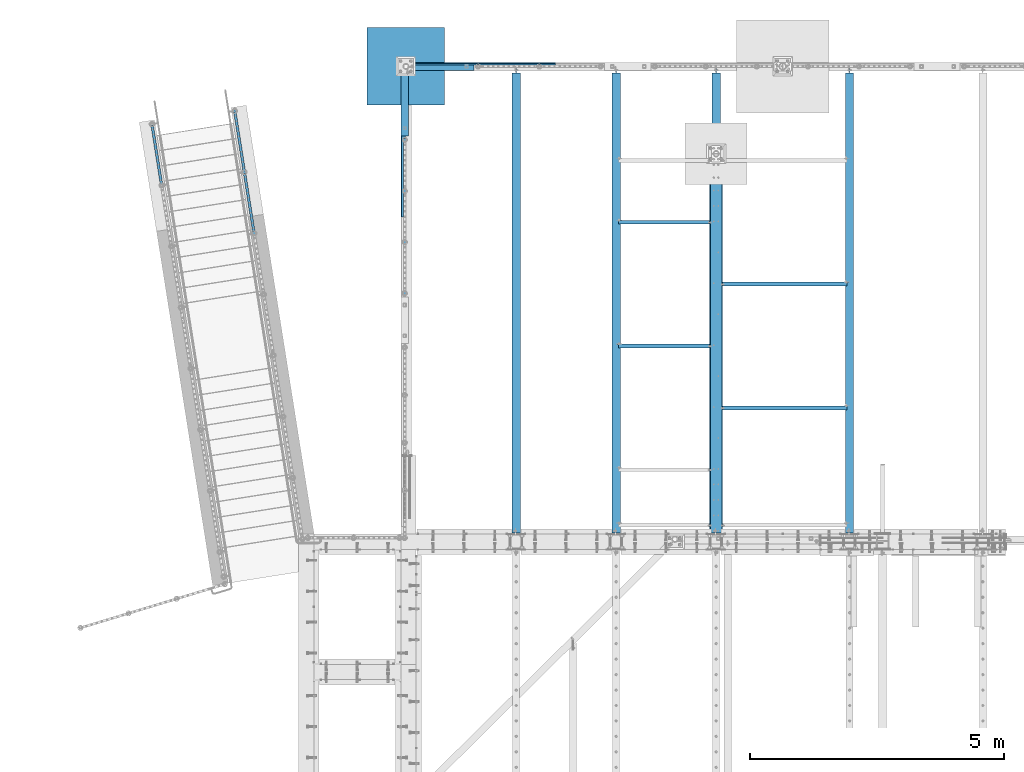
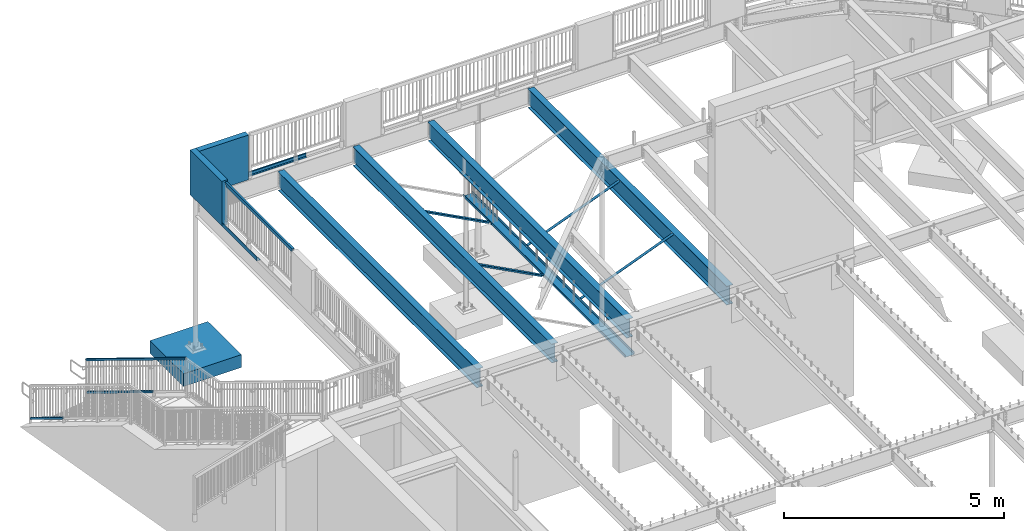
# One storey, part 324 of 975: 15 beams, 4 members.
"""IFC2X3 building model written with IfcOpenShell, lengths in millimetres."""

from ifc_helpers import new_model, si_unit, frame, origin_with_axes, place, context, subcontext, project, spatial, faceted_brep, material, type_object, element, save


model = new_model("IFC2X3")

# Units and contexts
model_context = context("Model", 3, precision=1e-05, world=origin_with_axes())
body_context = subcontext(model_context, "Body", "Model", "MODEL_VIEW")
ifc_project = project(units=[si_unit("LENGTHUNIT", "METRE", prefix="MILLI"), si_unit("AREAUNIT", "SQUARE_METRE"), si_unit("VOLUMEUNIT", "CUBIC_METRE"), si_unit("MASSUNIT", "GRAM", prefix="KILO"), si_unit("TIMEUNIT", "SECOND"), si_unit("PLANEANGLEUNIT", "RADIAN"), si_unit("SOLIDANGLEUNIT", "STERADIAN"), si_unit("THERMODYNAMICTEMPERATUREUNIT", "DEGREE_CELSIUS"), si_unit("LUMINOUSINTENSITYUNIT", "LUMEN")], contexts=[model_context])

# Site, building, storey
site_placement = place(None, origin_with_axes())
site = spatial("IfcSite", under=ifc_project, at=site_placement, CompositionType="ELEMENT")
building_placement = place(site_placement, origin_with_axes())
building = spatial("IfcBuilding", under=site, at=building_placement, Name="Undefined", CompositionType="ELEMENT")
storey_placement = place(building_placement, origin_with_axes())
storey = spatial("IfcBuildingStorey", under=building, at=storey_placement, Name="Undefined", CompositionType="ELEMENT", Elevation=0.0)

# Beams
ifc_material_1 = material(Name="STEEL/A36")
beam_type_1 = type_object("IfcBeamType", Name="L3X3X3/16", PredefinedType="NOTDEFINED")
for number, where, z_axis, x_axis, name in (
    (1, (8064.5, 24454.64375, 2870.2), (-0.999999999999998, 6.90000001668524e-08, 0.0), (0.0, 0.0, 1.0), "ANGLE"),
    (2, (8064.5, 26893.04375, 2870.2), (-0.999999999999998, 6.90000001668524e-08, 0.0), (0.0, 0.0, 1.0), "ANGLE"),
):
    element("IfcBeam", number, at=place(storey_placement, frame(where, z_axis=z_axis, x_axis=x_axis)), inside=storey, type_object=beam_type_1, material=ifc_material_1, Name=name, ObjectType="L3X3X3/16", context=body_context, shape_type="Brep", body=[
        faceted_brep([(46.1799589858119, 38.0999999999985, 38.1000000000004), (46.1799589858119, 33.3375000000015, 38.1000000000004), (972.720343066658, 33.3375000000015, 1789.57301067668), (972.720343066658, 38.0999999999985, 1789.57301067668), (26.0603826014149, 38.0999999999985, 0.0672324894812846), (26.0603826014149, 33.3375000000015, 0.0672324894812846), (89.2065642251332, 38.0999999999985, -33.3374999984389), (89.2065642251332, 33.3375000000015, -33.3374999984389), (1035.86652469034, 33.3375000000015, 1756.16827818882), (89.2065642281518, -38.0999999999985, -33.3374999999996), (1035.86652469042, -38.0999999999985, 1756.16827818877), (25.4000000000001, -38.0999999999985, -33.3374999999996), (25.4000000000001, -38.0999999999985, -38.1000000000004), (92.0750045776413, -38.0999999999985, -38.1000000000004), (1040.07627013201, -38.0999999999985, 1753.94129602291), (92.0750045776413, 38.0999999999985, -38.1000000000004), (25.4000000000001, 38.0999999999985, -38.1000000000004), (1040.07627013201, 38.0999999999985, 1753.94129602291), (25.4000000000001, 38.0999999999985, -33.337499282643), (25.4000000000001, 33.3375000000015, -33.3374999999996)], [[[0, 1, 2, 3]], [[1, 0, 4, 5]], [[5, 4, 6, 7]], [[1, 5, 7, 8, 2]], [[7, 9, 10, 8]], [[9, 11, 12, 13, 14, 10]], [[15, 13, 12, 16]], [[13, 15, 17, 14]], [[3, 2, 8, 10, 14, 17]], [[15, 16, 18, 6, 4, 0, 3, 17]], [[7, 6, 18, 19]], [[16, 12, 11, 19, 18]], [[9, 7, 19, 11]]]),
    ])
for number, where, z_axis, x_axis, name in (
    (3, (8394.7, 23235.44375, 2870.2), (0.0, -1.0, 0.0), (0.0, 0.0, 1.0), "ANGLE"),
    (4, (8394.7, 25673.84375, 2870.2), (0.0, -1.0, 0.0), (0.0, 0.0, 1.0), "ANGLE"),
):
    element("IfcBeam", number, at=place(storey_placement, frame(where, z_axis=z_axis, x_axis=x_axis)), inside=storey, type_object=beam_type_1, material=ifc_material_1, Name=name, ObjectType="L3X3X3/16", context=body_context, shape_type="Brep", body=[
        faceted_brep([(39.9761162779782, -38.1000000000186, -33.3375000000015), (39.9761162779782, -38.1000000000186, -38.0999999999985), (975.885837340196, -2441.28615210523, -38.0999999999985), (975.885837340196, -2441.28615210523, -33.3375000000015), (92.0750045805971, 38.0999999999585, 38.0999999999985), (92.0750045776413, 38.0999999999985, -38.1000000000004), (25.4000000000001, 38.0999999999985, -38.1000000000004), (25.4000000005876, 38.0999999999876, 38.0999999999985), (1046.89123738925, -2413.6334277571, 38.0999999999985), (1046.89123738925, -2413.6334277571, -38.0999999999985), (22.2348571728535, 7.45519597605016, -38.0999999999985), (88.8737698161085, 33.4074081533654, -38.0999999999985), (25.4037304659755, 33.357482595593, -38.0999999999985), (88.8737698161085, 33.4074081533654, -33.3375000000015), (22.2348571728535, 7.45519597605016, -33.3375000000015), (25.4037304659819, 33.3574825875421, -33.3375000000015), (25.4037304659746, 33.3574825966371, 38.0999999999985), (88.8188240616832, 33.3374999999596, 38.0999999999985), (1042.45405198512, -2415.36146907195, -33.3375000000015), (1042.45339988618, -2415.36172302886, 38.0999999999985)], [[[0, 1, 2, 3]], [[4, 5, 6, 7]], [[5, 4, 8, 9]], [[1, 10, 11, 12, 6, 5, 9, 2]], [[13, 11, 10, 14]], [[11, 13, 15, 12]], [[16, 7, 6, 12, 15]], [[13, 17, 16, 15]], [[17, 13, 18, 19]], [[4, 7, 16, 17, 19, 8]], [[18, 3, 2, 9, 8, 19]], [[13, 14, 0, 3, 18]], [[10, 1, 0, 14]]]),
    ])
beam_type_2 = type_object("IfcBeamType", Name="C10X15.3", PredefinedType="NOTDEFINED")
beam_1_placement = place(storey_placement, frame((8229.6, 20774.025, 2928.9375), z_axis=(-0.999999999999998, 6.90000001668524e-08, 0.0), x_axis=(0.0, 1.0, 0.0)))
element("IfcBeam", 5, at=beam_1_placement, inside=storey, type_object=beam_type_2, material=ifc_material_1, Name="BEAM", ObjectType="C10X15.3", context=body_context, shape_type="Brep", body=[
    faceted_brep([(-1.70985003933311e-10, 33.3375000000001, -126.999999999975), (1.78260961547494e-10, 33.3375000000001, 126.999999999975), (7391.40000000001, 33.3375000000001, 127.0), (7391.40000000001, 33.3375000000001, -127.0), (1.78260961547494e-10, -33.3375000000001, 126.999999999975), (7391.40000000001, -33.3375000000001, 127.0), (1.70985003933311e-10, -33.3375000000001, 121.441527499974), (7391.40000000001, -33.3375000000001, 121.4415275), (1.52795109897852e-10, 26.9875000000002, 111.391382499978), (7391.40000000001, 26.9875000000002, 111.3913825), (-1.4915713109076e-10, 26.9875000000002, -111.391382499976), (7391.40000000001, 26.9875000000002, -111.3913825), (-1.63709046319127e-10, -33.3375000000001, -121.44152749997), (7391.40000000001, -33.3375000000001, -121.441527499999), (-1.70985003933311e-10, -33.3375000000001, -126.999999999975), (7391.40000000001, -33.3375000000001, -127.0)], [[[0, 1, 2, 3]], [[1, 4, 5, 2]], [[4, 6, 7, 5]], [[6, 8, 9, 7]], [[8, 10, 11, 9]], [[10, 12, 13, 11]], [[12, 14, 15, 13]], [[14, 0, 3, 15]], [[5, 7, 9, 11, 13, 15, 3, 2]], [[14, 12, 10, 8, 6, 4, 1, 0]]]),
])

# Members
ifc_material_2 = material()
member_type = type_object("IfcMemberType", Name="HSS2X2X.188_TUBES", PredefinedType="NOTDEFINED")
member_1_placement = place(storey_placement, frame((-2693.3874758683, 27609.317791049, 852.529447443305), z_axis=(-0.987688340611262, -0.156434464938429, 0.0), x_axis=(-0.136949714005939, 0.864666463037498, -0.48331840802096)))
element("IfcMember", 6, at=member_1_placement, inside=storey, type_object=member_type, material=ifc_material_2, Name="HANDRAIL", ObjectType="HSS2X2X.188_TUBES", context=body_context, shape_type="Brep", body=[
    faceted_brep([(54.4302474242504, 20.6375000000626, -20.6374999999853), (31.6430072086805, -20.6374999999716, -20.6374999999978), (1366.27920221516, -20.6374999989694, -20.6374999998329), (1389.06644232434, 20.6375000010648, -20.63749999982), (31.6430072202093, -20.6374999999971, 20.6374999999955), (1366.27920222668, -20.637499998993, 20.6375000001603), (54.4302474357719, 20.6375000000389, 20.6375000000089), (1389.06644233586, 20.637500001043, 20.6375000001738), (57.0595443708662, 25.4000000000669, -25.3999999999828), (57.0595443850543, 25.4000000000397, 25.4000000000096), (1391.69573927287, 25.4000000010419, 25.4000000001743), (1391.69573925868, 25.4000000010692, -25.3999999998173), (29.0137102735862, -25.4000000000051, 25.3999999999933), (1363.64990529234, -25.3999999989992, 25.4000000001583), (29.0137102594053, -25.3999999999742, -25.3999999999996), (1363.64990527816, -25.3999999989737, -25.3999999998337)], [[[0, 1, 2, 3]], [[1, 4, 5, 2]], [[4, 6, 7, 5]], [[6, 0, 3, 7]], [[8, 9, 10, 11]], [[9, 12, 13, 10]], [[12, 14, 15, 13]], [[14, 8, 11, 15]], [[13, 15, 11, 10], [5, 7, 3, 2]], [[14, 12, 9, 8], [6, 4, 1, 0]]]),
])
member_2_placement = place(storey_placement, frame((-1062.51984067464, 27867.6218487024, 852.529447443337), z_axis=(0.987688352468583, 0.156434390074216, -6.09999983468464e-08), x_axis=(-0.136949714005939, 0.864666463037498, -0.48331840802096)))
element("IfcMember", 7, at=member_2_placement, inside=storey, type_object=member_type, material=ifc_material_2, Name="HANDRAIL", ObjectType="HSS2X2X.188_TUBES", context=body_context, shape_type="Brep", body=[
    faceted_brep([(31.6430015744991, 20.6374999999971, -20.6375000000071), (54.4302415156744, -20.6375000000389, -20.6375000000171), (1389.0664456711, -20.6375000007483, -20.6375000003263), (1366.27920529597, 20.6374999992768, -20.6375000003163), (54.4302415041384, -20.6375000000608, 20.6374999999771), (1389.06644565957, -20.6375000007738, 20.6374999996651), (31.6430015629558, 20.6374999999734, 20.6374999999862), (1366.27920528444, 20.6374999992513, 20.6374999996756), (29.013704659541, 25.4000000000015, -25.4000000000065), (29.0137046453419, 25.3999999999778, 25.3999999999869), (1363.64990831675, 25.3999999992502, 25.3999999996763), (1363.64990833094, 25.3999999992848, -25.4000000003134), (57.0595384190929, -25.4000000000688, 25.3999999999755), (1391.6957426246, -25.4000000007818, 25.3999999996622), (57.0595384332955, -25.4000000000397, -25.4000000000165), (1391.69574263879, -25.4000000007491, -25.4000000003266)], [[[0, 1, 2, 3]], [[1, 4, 5, 2]], [[4, 6, 7, 5]], [[6, 0, 3, 7]], [[8, 9, 10, 11]], [[9, 12, 13, 10]], [[12, 14, 15, 13]], [[14, 8, 11, 15]], [[13, 15, 11, 10], [5, 7, 3, 2]], [[14, 12, 9, 8], [6, 4, 1, 0]]]),
])
member_3_placement = place(storey_placement, frame((-871.794940906256, 26663.4322235995, 1525.62946625253), z_axis=(0.987688352468583, 0.156434390074216, -6.09999983468464e-08), x_axis=(-0.136949714005939, 0.864666463037498, -0.48331840802096)))
element("IfcMember", 8, at=member_3_placement, inside=storey, type_object=member_type, material=ifc_material_2, Name="HANDRAIL", ObjectType="HSS2X2X.188_TUBES", context=body_context, shape_type="Brep", body=[
    faceted_brep([(31.6431248042572, 20.6375000000044, -20.6375000000007), (54.430365019809, -20.6375000000226, -20.6375000000116), (1389.06632007801, -20.6375000010266, -20.6375000003268), (1366.27908013683, 20.6374999990039, -20.6375000003159), (54.4303650082802, -20.6375000000462, 20.6374999999803), (1389.06632006648, -20.6375000010466, 20.6374999996674), (31.6431247927285, 20.6374999999753, 20.6374999999907), (1366.2790801253, 20.6374999989821, 20.6374999996774), (29.0138278576378, 25.4000000000106, -25.3999999999983), (29.0138278434497, 25.399999999976, 25.3999999999915), (1363.64978320768, 25.3999999989865, 25.3999999996786), (1363.64978322187, 25.3999999990083, -25.4000000003134), (57.0596619548996, -25.4000000000524, 25.3999999999778), (1391.69561698143, -25.400000001051, 25.3999999996649), (57.0596619690841, -25.4000000000233, -25.4000000000124), (1391.69561699563, -25.4000000010292, -25.400000000328)], [[[0, 1, 2, 3]], [[1, 4, 5, 2]], [[4, 6, 7, 5]], [[6, 0, 3, 7]], [[8, 9, 10, 11]], [[9, 12, 13, 10]], [[12, 14, 15, 13]], [[14, 8, 11, 15]], [[13, 15, 11, 10], [5, 7, 3, 2]], [[14, 12, 9, 8], [6, 4, 1, 0]]]),
])
member_4_placement = place(storey_placement, frame((-692.99034802493, 25534.5044502162, 3063.86370431404), z_axis=(0.987688352468583, 0.156434390074216, -6.09999983468464e-08), x_axis=(-0.136949714005939, 0.864666463037498, -0.48331840802096)))
element("IfcMember", 9, at=member_4_placement, inside=storey, type_object=member_type, material=ifc_material_2, Name="HANDRAIL", ObjectType="HSS2X2X.188_TUBES", context=body_context, shape_type="Brep", body=[
    faceted_brep([(1.22733805137614, 20.6375000000317, -20.6374999999935), (11.8646581697139, -20.6374999999971, -20.637500000003), (4092.79252127036, -20.6375000022199, -20.6375000009657), (4117.15275125422, 20.6374999977797, -20.6375000009662), (11.8646582142646, -20.6375000000262, 20.6374999999907), (4092.79252125882, -20.6375000022454, 20.6374999990276), (1.2273376937701, 20.6375000000044, 20.6374999999994), (4117.15275124268, 20.6374999977543, 20.637499999028), (0.0, 25.3999999999724, -25.4000000000342), (0.0, 25.400000000016, 25.4000000000196), (4119.96354700871, 25.3999999977495, 25.3999999990265), (4119.96354702291, 25.3999999977841, -25.4000000009655), (13.0920366486134, -25.4000000000306, 25.3999999999892), (4089.98172549011, -25.4000000022497, 25.3999999990265), (13.0920365937782, -25.399999999996, -25.4000000000037), (4089.98172550431, -25.400000002217, -25.4000000009655)], [[[0, 1, 2, 3]], [[1, 4, 5, 2]], [[4, 6, 7, 5]], [[6, 0, 3, 7]], [[8, 9, 10, 11]], [[9, 12, 13, 10]], [[12, 14, 15, 13]], [[14, 8, 11, 15]], [[13, 15, 11, 10], [5, 7, 3, 2]], [[14, 12, 9, 8], [6, 4, 1, 0]]]),
])

# Beams
beam_type_3 = type_object("IfcBeamType", Name="HSS2X4X.188_TUBES", PredefinedType="NOTDEFINED")
beam_2_placement = place(storey_placement, frame((2092.25863996588, 25492.0780715938, 5130.8), z_axis=(0.0, 0.0, 1.0), x_axis=(5.97450000128461e-05, 0.999999998215263, 9.39999997701599e-08)))
element("IfcBeam", 10, at=beam_2_placement, inside=storey, type_object=beam_type_3, material=ifc_material_2, Name="GUARDRAIL", ObjectType="HSS2X4X.188_TUBES", context=body_context, shape_type="Brep", body=[
    faceted_brep([(23.0201356913603, 20.6375000000066, -46.0375000000004), (23.0201356707403, -20.637499999998, -46.0375000000004), (2999.57679778689, -20.6374999994505, -46.0375000000004), (2999.57679778687, 20.6375000005537, -46.0375000000004), (-23.0201344869965, -20.6375000000062, 46.0375000000004), (3045.61706784169, -20.6374999994423, 46.0375000000004), (-23.0201344663728, 20.637499999998, 46.0375000000004), (3045.61706784167, 20.6375000005623, 46.0375000000004), (25.4015289777599, 25.4000000000078, -50.8000000000002), (-25.4015277480175, 25.3999999999983, 50.8000000000002), (3047.99846112037, 25.4000000005635, 50.8000000000002), (2997.19540450817, 25.400000000554, -50.8000000000002), (-25.4015277733961, -25.4000000000074, 50.8000000000002), (3047.99846112038, -25.3999999994421, 50.8000000000002), (25.4015289523813, -25.3999999999983, -50.8000000000002), (2997.1954045082, -25.3999999994517, -50.8000000000002)], [[[0, 1, 2, 3]], [[1, 4, 5, 2]], [[4, 6, 7, 5]], [[6, 0, 3, 7]], [[8, 9, 10, 11]], [[9, 12, 13, 10]], [[12, 14, 15, 13]], [[14, 8, 11, 15]], [[13, 15, 11, 10], [5, 7, 3, 2]], [[14, 12, 9, 8], [6, 4, 1, 0]]]),
])
beam_type_4 = type_object("IfcBeamType", PredefinedType="NOTDEFINED")
beam_3_placement = place(storey_placement, frame((3540.20341487034, 29987.8750007629, 3938.58749694824), z_axis=(1.0, 0.0, 0.0), x_axis=(0.0, 1.0, 0.0)))
element("IfcBeam", 11, at=beam_3_placement, inside=storey, type_object=beam_type_4, material=ifc_material_1, Name="DECK_EDGE", context=body_context, shape_type="Brep", body=[
    faceted_brep([(1.03318598121405e-09, -1.58750000000009, -1524.00000000109), (-1.04046193882823e-09, -1.58750000000009, 1524.0000000011), (-1.04046193882823e-09, 1.58750000000009, 1524.0000000011), (1.03318598121405e-09, 1.58750000000009, -1524.00000000109), (47.6250001214066, 1.58750000000009, 1524.00000000113), (47.6250001235167, 1.58750000000009, -1524.00000000107), (50.8000001235196, -1.58750000000009, -1524.00000000106), (50.8000001214168, -1.58750000000009, 1524.00000000113), (47.6250001214503, 96.837499999901, 1524.00000000113), (47.625000123473, 96.8374999999951, -1524.00000000106), (50.8000001234759, 104.502628762961, -1524.00000000106), (50.8000001214605, 104.502628762867, 1524.00000000113), (38.6447461584321, 87.8572448731024, 1524.00000000113), (38.6447461604548, 87.8572448731024, -1524.00000000107), (36.3996819826862, 90.102308757891, 1524.00000000112), (36.3996819847016, 90.102308757891, -1524.00000000107)], [[[0, 1, 2, 3]], [[3, 2, 4, 5]], [[1, 0, 6, 7]], [[5, 4, 8, 9]], [[7, 6, 10, 11]], [[9, 8, 12, 13]], [[8, 4, 2, 1, 7, 11, 14, 12]], [[11, 10, 15, 14]], [[10, 6, 0, 3, 5, 9, 13, 15]], [[14, 15, 13, 12]]]),
])
beam_type_5 = type_object("IfcBeamType", PredefinedType="NOTDEFINED")
beam_4_placement = place(storey_placement, frame((2105.02499923706, 28514.7534148703, 3938.58749694824), z_axis=(0.0, 1.0, 0.0), x_axis=(-0.999999999999998, 6.90000001668524e-08, 0.0)))
element("IfcBeam", 12, at=beam_4_placement, inside=storey, type_object=beam_type_5, material=ifc_material_1, Name="DECK_EDGE", context=body_context, shape_type="Brep", body=[
    faceted_brep([(1.03318598121405e-09, -1.58750000000009, -1524.00000000109), (-1.04046193882823e-09, -1.58750000000009, 1524.0000000011), (-1.04046193882823e-09, 1.58750000000009, 1524.0000000011), (1.03318598121405e-09, 1.58750000000009, -1524.00000000109), (85.7250061035156, 1.58750000000009, 1524.0), (85.7250061035156, 1.58750000000009, -1524.0), (88.9000061035158, -1.58750000000009, -1524.0), (88.9000061035158, -1.58750000000009, 1524.0), (85.7250061035156, 96.8375000000005, 1524.0), (85.7250061035156, 96.8375000000005, -1524.0), (88.9000061035158, 104.502628060535, -1524.0), (88.9000061035158, 104.502628060535, 1524.0), (76.7447509765625, 87.857244873047, 1524.0), (76.7447509765625, 87.857244873047, -1524.0), (74.4996869462952, 90.1023089033147, 1524.0), (74.4996869462952, 90.1023089033147, -1524.0)], [[[0, 1, 2, 3]], [[3, 2, 4, 5]], [[1, 0, 6, 7]], [[5, 4, 8, 9]], [[7, 6, 10, 11]], [[9, 8, 12, 13]], [[8, 4, 2, 1, 7, 11, 14, 12]], [[11, 10, 15, 14]], [[10, 6, 0, 3, 5, 9, 13, 15]], [[14, 15, 13, 12]]]),
])
ifc_material_3 = material(Name="CONCRETE/5000")
beam_type_6 = type_object("IfcBeamType", PredefinedType="NOTDEFINED")
beam_5_placement = place(storey_placement, frame((2092.325, 30038.675, 4559.3), z_axis=(0.0, 0.0, 1.0), x_axis=(0.0, -1.0, 0.0)))
element("IfcBeam", 13, at=beam_5_placement, inside=storey, type_object=beam_type_6, material=ifc_material_3, Name="LOW WALL", context=body_context, shape_type="Brep", body=[
    faceted_brep([(1.0550138540566e-10, 76.1999999999316, -622.3), (1.0550138540566e-10, 76.1999999999316, 622.3), (1447.8, 76.1999999999998, 622.3), (1447.8, 76.1999999999998, -622.3), (-1.01863406598568e-10, -76.1999999999243, 622.3), (1447.8, -76.2, 622.3), (-1.01863406598568e-10, -76.1999999999243, -622.3), (1447.8, -76.2, -622.3)], [[[0, 1, 2, 3]], [[1, 4, 5, 2]], [[4, 6, 7, 5]], [[6, 0, 3, 7]], [[5, 7, 3, 2]], [[6, 4, 1, 0]]]),
])
beam_6_placement = place(storey_placement, frame((2016.125, 29962.475, 4559.3), z_axis=(0.0, 0.0, 1.0), x_axis=(1.0, 0.0, 0.0)))
element("IfcBeam", 14, at=beam_6_placement, inside=storey, type_object=beam_type_6, material=ifc_material_3, Name="LOW WALL", context=body_context, shape_type="Brep", body=[
    faceted_brep([(1.0550138540566e-10, 76.1999999999316, -622.3), (1.0550138540566e-10, 76.1999999999316, 622.3), (1447.35177609106, 76.2000000000007, 622.3), (1447.35177609106, 76.2000000000007, -622.3), (-1.01863406598568e-10, -76.1999999999243, 622.3), (1447.35177609106, -76.2000000000007, 622.3), (-1.01863406598568e-10, -76.1999999999243, -622.3), (1447.35177609106, -76.2000000000007, -622.3)], [[[0, 1, 2, 3]], [[1, 4, 5, 2]], [[4, 6, 7, 5]], [[6, 0, 3, 7]], [[5, 7, 3, 2]], [[6, 4, 1, 0]]]),
])
beam_type_7 = type_object("IfcBeamType", PredefinedType="NOTDEFINED")
beam_7_placement = place(storey_placement, frame((1355.72500846572, 29962.475023622, -482.6), z_axis=(0.0, 0.0, 1.0), x_axis=(1.0, 0.0, 0.0)))
element("IfcBeam", 15, at=beam_7_placement, inside=storey, type_object=beam_type_7, material=ifc_material_3, Name="FOOTING", context=body_context, shape_type="Brep", body=[
    faceted_brep([(4.8748916015029e-10, 762.000000001049, -177.8), (4.8748916015029e-10, 762.000000001049, 177.8), (1524.00000000259, 762.000000000074, 177.8), (1524.00000000259, 762.000000000074, -177.8), (-4.80213202536106e-10, -762.000000001047, 177.8), (1524.00000000162, -762.00000000202, 177.8), (-4.80213202536106e-10, -762.000000001047, -177.8), (1524.00000000162, -762.00000000202, -177.8)], [[[0, 1, 2, 3]], [[1, 4, 5, 2]], [[4, 6, 7, 5]], [[6, 0, 3, 7]], [[5, 7, 3, 2]], [[6, 4, 1, 0]]]),
])
ifc_material_4 = material(Name="STEEL/A992")
beam_type_8 = type_object("IfcBeamType", Name="W21X44", PredefinedType="NOTDEFINED")
beam_8_placement = place(storey_placement, frame((10858.5, 20748.625, 3675.0625), z_axis=(0.0, 0.0, 1.0), x_axis=(0.0, 1.0, 0.0)))
element("IfcBeam", 16, at=beam_8_placement, inside=storey, type_object=beam_type_8, material=ifc_material_4, Name="BEAM", ObjectType="W21X44", context=body_context, shape_type="Brep", body=[
    faceted_brep([(9177.3375, -4.76250000000073, 236.5375), (9177.3375, 4.76250000000073, 236.5375), (9101.13749980927, 4.76250000000073, 236.5375), (9101.13749980927, -4.76250000000073, 236.5375), (9096.27742029122, 4.76250000000073, 237.504229922588), (9096.27742029122, -4.76250000000073, 237.504229922588), (9092.15724382307, 4.76250000000073, 240.257243823066), (9092.15724382307, -4.76250000000073, 240.257243823066), (9089.40422992259, 4.76250000000073, 244.37742029122), (9089.40422992259, -4.76250000000073, 244.37742029122), (9088.4375, 4.76250000000073, 249.237499809265), (9088.4375, -4.76250000000073, 249.237499809265), (25.4000000000015, -82.5499999999993, 250.825), (25.4000000000015, -4.76250000000073, 250.825), (9088.4375, -4.76250000000073, 250.825), (9088.4375, -82.5499999999993, 250.825), (25.4000000000015, -82.5499999999993, 261.9375), (9088.4375, -82.5499999999993, 261.9375), (25.4000000000015, 82.5499999999993, 261.9375), (9088.4375, 82.5499999999993, 261.9375), (9082.0875, 82.5499999999993, 250.825), (25.4000000000015, 82.5499999999993, 250.825), (9088.4375, 82.5499999999993, 250.825), (9088.4375, 4.76250000000073, 250.825), (9082.0875, 4.76250000000073, 250.825), (25.4000000000015, 4.76250000000073, 250.825), (25.4000000000015, -82.5499999999993, -261.9375), (25.4000000000015, -82.5499999999993, -250.825), (25.4000000000015, -4.76250000000073, -250.825), (25.4000000000015, 4.76250000000073, -250.825), (25.4000000000015, 82.5499999999993, -250.825), (25.4000000000015, 82.5499999999993, -261.9375), (9075.7375, 4.76250000000073, -250.825), (9075.7375, 82.5499999999993, -250.825), (9075.7375, 82.5499999999993, -261.9375), (9075.7375, -82.5499999999993, -261.9375), (9075.7375, -82.5499999999993, -250.825), (9075.7375, -4.76250000000073, -250.825), (9075.7375, -4.76250000000073, -249.237499809265), (9076.70422992259, -4.76250000000073, -244.37742029122), (9079.45724382307, -4.76250000000073, -240.257243823066), (9083.57742029122, -4.76250000000073, -237.504229922588), (9088.43749980927, -4.76250000000073, -236.5375), (9177.3375, -4.76250000000073, -236.5375), (9177.3375, 4.76250000000073, -236.5375), (9083.57742029122, 4.76250000000073, -237.504229922588), (9079.45724382307, 4.76250000000073, -240.257243823066), (9076.70422992259, 4.76250000000073, -244.37742029122), (9075.7375, 4.76250000000073, -249.237499809265), (9088.43749980927, 4.76250000000073, -236.5375)], [[[0, 1, 2, 3]], [[3, 2, 4, 5]], [[5, 4, 6, 7]], [[7, 6, 8, 9]], [[9, 8, 10, 11]], [[12, 13, 14, 15]], [[16, 12, 15, 17]], [[18, 16, 17, 19]], [[20, 21, 18, 19, 22]], [[17, 15, 14, 11, 10, 23, 22, 19]], [[24, 25, 21, 20, 22, 23]], [[26, 27, 28, 13, 12, 16, 18, 21, 25, 29, 30, 31]], [[30, 29, 32, 33]], [[31, 30, 33, 34]], [[26, 31, 34, 35]], [[27, 26, 35, 36]], [[28, 27, 36, 37]], [[0, 3, 5, 7, 9, 11, 14, 13, 28, 37, 38, 39, 40, 41, 42, 43]], [[1, 0, 43, 44]], [[45, 46, 47, 48, 32, 29, 25, 24, 23, 10, 8, 6, 4, 2, 1, 44, 49]], [[43, 42, 49, 44]], [[41, 45, 49, 42]], [[40, 46, 45, 41]], [[39, 47, 46, 40]], [[38, 48, 47, 39]], [[37, 36, 35, 34, 33, 32, 48, 38]]]),
])
beam_9_placement = place(storey_placement, frame((4290.48345841015, 20748.625, 3675.0625), z_axis=(0.0, 0.0, 1.0), x_axis=(0.0, 1.0, 0.0)))
element("IfcBeam", 17, at=beam_9_placement, inside=storey, type_object=beam_type_8, material=ifc_material_4, Name="BEAM", ObjectType="W21X44", context=body_context, shape_type="Brep", body=[
    faceted_brep([(9177.3375, -4.76250000000073, 236.5375), (9177.3375, 4.76250000000073, 236.5375), (9101.13749980927, 4.76250000000073, 236.5375), (9101.13749980927, -4.76250000000073, 236.5375), (9096.27742029122, 4.76250000000073, 237.504229922588), (9096.27742029122, -4.76250000000073, 237.504229922588), (9092.15724382307, 4.76250000000073, 240.257243823066), (9092.15724382307, -4.76250000000073, 240.257243823066), (9089.40422992259, 4.76250000000073, 244.37742029122), (9089.40422992259, -4.76250000000073, 244.37742029122), (9088.4375, 4.76250000000073, 249.237499809265), (9088.4375, -4.76250000000073, 249.237499809265), (25.4000000000015, -82.5499999999993, 250.825), (25.4000000000015, -4.76250000000073, 250.825), (9088.4375, -4.76250000000073, 250.825), (9088.4375, -82.5499999999993, 250.825), (25.4000000000015, -82.5499999999993, 261.9375), (9088.4375, -82.5499999999993, 261.9375), (25.4000000000015, 82.5499999999993, 261.9375), (9088.4375, 82.5499999999993, 261.9375), (9082.0875, 82.5499999999993, 250.825), (25.4000000000015, 82.5499999999993, 250.825), (9088.4375, 82.5499999999993, 250.825), (9088.4375, 4.76250000000073, 250.825), (9082.0875, 4.76250000000073, 250.825), (25.4000000000015, 4.76250000000073, 250.825), (25.4000000000015, -82.5499999999993, -261.9375), (25.4000000000015, -82.5499999999993, -250.825), (25.4000000000015, -4.76250000000073, -250.825), (25.4000000000015, 4.76250000000073, -250.825), (25.4000000000015, 82.5499999999993, -250.825), (25.4000000000015, 82.5499999999993, -261.9375), (9075.7375, 4.76250000000073, -250.825), (9075.7375, 82.5499999999993, -250.825), (9075.7375, 82.5499999999993, -261.9375), (9075.7375, -82.5499999999993, -261.9375), (9075.7375, -82.5499999999993, -250.825), (9075.7375, -4.76250000000073, -250.825), (9075.7375, -4.76250000000073, -249.237499809265), (9076.70422992259, -4.76250000000073, -244.37742029122), (9079.45724382307, -4.76250000000073, -240.257243823066), (9083.57742029122, -4.76250000000073, -237.504229922588), (9088.43749980927, -4.76250000000073, -236.5375), (9177.3375, -4.76250000000073, -236.5375), (9177.3375, 4.76250000000073, -236.5375), (9083.57742029122, 4.76250000000073, -237.504229922588), (9079.45724382307, 4.76250000000073, -240.257243823066), (9076.70422992259, 4.76250000000073, -244.37742029122), (9075.7375, 4.76250000000073, -249.237499809265), (9088.43749980927, 4.76250000000073, -236.5375)], [[[0, 1, 2, 3]], [[3, 2, 4, 5]], [[5, 4, 6, 7]], [[7, 6, 8, 9]], [[9, 8, 10, 11]], [[12, 13, 14, 15]], [[16, 12, 15, 17]], [[18, 16, 17, 19]], [[20, 21, 18, 19, 22]], [[17, 15, 14, 11, 10, 23, 22, 19]], [[24, 25, 21, 20, 22, 23]], [[26, 27, 28, 13, 12, 16, 18, 21, 25, 29, 30, 31]], [[30, 29, 32, 33]], [[31, 30, 33, 34]], [[26, 31, 34, 35]], [[27, 26, 35, 36]], [[28, 27, 36, 37]], [[0, 3, 5, 7, 9, 11, 14, 13, 28, 37, 38, 39, 40, 41, 42, 43]], [[1, 0, 43, 44]], [[45, 46, 47, 48, 32, 29, 25, 24, 23, 10, 8, 6, 4, 2, 1, 44, 49]], [[43, 42, 49, 44]], [[41, 45, 49, 42]], [[40, 46, 45, 41]], [[39, 47, 46, 40]], [[38, 48, 47, 39]], [[37, 36, 35, 34, 33, 32, 48, 38]]]),
])
beam_10_placement = place(storey_placement, frame((6260.04172920507, 20748.625, 3675.0625), z_axis=(0.0, 0.0, 1.0), x_axis=(0.0, 1.0, 0.0)))
element("IfcBeam", 18, at=beam_10_placement, inside=storey, type_object=beam_type_8, material=ifc_material_4, Name="BEAM", ObjectType="W21X44", context=body_context, shape_type="Brep", body=[
    faceted_brep([(9177.3375, -4.76250000000073, 236.5375), (9177.3375, 4.76250000000073, 236.5375), (9101.13749980927, 4.76250000000073, 236.5375), (9101.13749980927, -4.76250000000073, 236.5375), (9096.27742029122, 4.76250000000073, 237.504229922588), (9096.27742029122, -4.76250000000073, 237.504229922588), (9092.15724382307, 4.76250000000073, 240.257243823066), (9092.15724382307, -4.76250000000073, 240.257243823066), (9089.40422992259, 4.76250000000073, 244.37742029122), (9089.40422992259, -4.76250000000073, 244.37742029122), (9088.4375, 4.76250000000073, 249.237499809265), (9088.4375, -4.76250000000073, 249.237499809265), (25.4000000000015, -82.5499999999993, 250.825), (25.4000000000015, -4.76250000000073, 250.825), (9088.4375, -4.76250000000073, 250.825), (9088.4375, -82.5499999999993, 250.825), (25.4000000000015, -82.5499999999993, 261.9375), (9088.4375, -82.5499999999993, 261.9375), (25.4000000000015, 82.5499999999993, 261.9375), (9088.4375, 82.5499999999993, 261.9375), (9082.0875, 82.5499999999993, 250.825), (25.4000000000015, 82.5499999999993, 250.825), (9088.4375, 82.5499999999993, 250.825), (9088.4375, 4.76250000000073, 250.825), (9082.0875, 4.76250000000073, 250.825), (25.4000000000015, 4.76250000000073, 250.825), (25.4000000000015, -82.5499999999993, -261.9375), (25.4000000000015, -82.5499999999993, -250.825), (25.4000000000015, -4.76250000000073, -250.825), (25.4000000000015, 4.76250000000073, -250.825), (25.4000000000015, 82.5499999999993, -250.825), (25.4000000000015, 82.5499999999993, -261.9375), (9075.7375, 4.76250000000073, -250.825), (9075.7375, 82.5499999999993, -250.825), (9075.7375, 82.5499999999993, -261.9375), (9075.7375, -82.5499999999993, -261.9375), (9075.7375, -82.5499999999993, -250.825), (9075.7375, -4.76250000000073, -250.825), (9075.7375, -4.76250000000073, -249.237499809265), (9076.70422992259, -4.76250000000073, -244.37742029122), (9079.45724382307, -4.76250000000073, -240.257243823066), (9083.57742029122, -4.76250000000073, -237.504229922588), (9088.43749980927, -4.76250000000073, -236.5375), (9177.3375, -4.76250000000073, -236.5375), (9177.3375, 4.76250000000073, -236.5375), (9083.57742029122, 4.76250000000073, -237.504229922588), (9079.45724382307, 4.76250000000073, -240.257243823066), (9076.70422992259, 4.76250000000073, -244.37742029122), (9075.7375, 4.76250000000073, -249.237499809265), (9088.43749980927, 4.76250000000073, -236.5375)], [[[0, 1, 2, 3]], [[3, 2, 4, 5]], [[5, 4, 6, 7]], [[7, 6, 8, 9]], [[9, 8, 10, 11]], [[12, 13, 14, 15]], [[16, 12, 15, 17]], [[18, 16, 17, 19]], [[20, 21, 18, 19, 22]], [[17, 15, 14, 11, 10, 23, 22, 19]], [[24, 25, 21, 20, 22, 23]], [[26, 27, 28, 13, 12, 16, 18, 21, 25, 29, 30, 31]], [[30, 29, 32, 33]], [[31, 30, 33, 34]], [[26, 31, 34, 35]], [[27, 26, 35, 36]], [[28, 27, 36, 37]], [[0, 3, 5, 7, 9, 11, 14, 13, 28, 37, 38, 39, 40, 41, 42, 43]], [[1, 0, 43, 44]], [[45, 46, 47, 48, 32, 29, 25, 24, 23, 10, 8, 6, 4, 2, 1, 44, 49]], [[43, 42, 49, 44]], [[41, 45, 49, 42]], [[40, 46, 45, 41]], [[39, 47, 46, 40]], [[38, 48, 47, 39]], [[37, 36, 35, 34, 33, 32, 48, 38]]]),
])
beam_11_placement = place(storey_placement, frame((8229.6, 20748.625, 3675.0625), z_axis=(0.0, 0.0, 1.0), x_axis=(0.0, 1.0, 0.0)))
element("IfcBeam", 19, at=beam_11_placement, inside=storey, type_object=beam_type_8, material=ifc_material_4, Name="BEAM", ObjectType="W21X44", context=body_context, shape_type="Brep", body=[
    faceted_brep([(9177.3375, -4.76250000000073, 236.5375), (9177.3375, 4.76250000000073, 236.5375), (9101.13749980927, 4.76250000000073, 236.5375), (9101.13749980927, -4.76250000000073, 236.5375), (9096.27742029122, 4.76250000000073, 237.504229922588), (9096.27742029122, -4.76250000000073, 237.504229922588), (9092.15724382307, 4.76250000000073, 240.257243823066), (9092.15724382307, -4.76250000000073, 240.257243823066), (9089.40422992259, 4.76250000000073, 244.37742029122), (9089.40422992259, -4.76250000000073, 244.37742029122), (9088.4375, 4.76250000000073, 249.237499809265), (9088.4375, -4.76250000000073, 249.237499809265), (25.4000000000015, -82.5499999999993, 250.825), (25.4000000000015, -4.76250000000073, 250.825), (9088.4375, -4.76250000000073, 250.825), (9088.4375, -82.5499999999993, 250.825), (25.4000000000015, -82.5499999999993, 261.9375), (9088.4375, -82.5499999999993, 261.9375), (25.4000000000015, 82.5499999999993, 261.9375), (9088.4375, 82.5499999999993, 261.9375), (9082.0875, 82.5499999999993, 250.825), (25.4000000000015, 82.5499999999993, 250.825), (9088.4375, 82.5499999999993, 250.825), (9088.4375, 4.76250000000073, 250.825), (9082.0875, 4.76250000000073, 250.825), (25.4000000000015, 4.76250000000073, 250.825), (25.4000000000015, -82.5499999999993, -261.9375), (25.4000000000015, -82.5499999999993, -250.825), (25.4000000000015, -4.76250000000073, -250.825), (25.4000000000015, 4.76250000000073, -250.825), (25.4000000000015, 82.5499999999993, -250.825), (25.4000000000015, 82.5499999999993, -261.9375), (9075.7375, 4.76250000000073, -250.825), (9075.7375, 82.5499999999993, -250.825), (9075.7375, 82.5499999999993, -261.9375), (9075.7375, -82.5499999999993, -261.9375), (9075.7375, -82.5499999999993, -250.825), (9075.7375, -4.76250000000073, -250.825), (9075.7375, -4.76250000000073, -249.237499809265), (9076.70422992259, -4.76250000000073, -244.37742029122), (9079.45724382307, -4.76250000000073, -240.257243823066), (9083.57742029122, -4.76250000000073, -237.504229922588), (9088.43749980927, -4.76250000000073, -236.5375), (9177.3375, -4.76250000000073, -236.5375), (9177.3375, 4.76250000000073, -236.5375), (9083.57742029122, 4.76250000000073, -237.504229922588), (9079.45724382307, 4.76250000000073, -240.257243823066), (9076.70422992259, 4.76250000000073, -244.37742029122), (9075.7375, 4.76250000000073, -249.237499809265), (9088.43749980927, 4.76250000000073, -236.5375)], [[[0, 1, 2, 3]], [[3, 2, 4, 5]], [[5, 4, 6, 7]], [[7, 6, 8, 9]], [[9, 8, 10, 11]], [[12, 13, 14, 15]], [[16, 12, 15, 17]], [[18, 16, 17, 19]], [[20, 21, 18, 19, 22]], [[17, 15, 14, 11, 10, 23, 22, 19]], [[24, 25, 21, 20, 22, 23]], [[26, 27, 28, 13, 12, 16, 18, 21, 25, 29, 30, 31]], [[30, 29, 32, 33]], [[31, 30, 33, 34]], [[26, 31, 34, 35]], [[27, 26, 35, 36]], [[28, 27, 36, 37]], [[0, 3, 5, 7, 9, 11, 14, 13, 28, 37, 38, 39, 40, 41, 42, 43]], [[1, 0, 43, 44]], [[45, 46, 47, 48, 32, 29, 25, 24, 23, 10, 8, 6, 4, 2, 1, 44, 49]], [[43, 42, 49, 44]], [[41, 45, 49, 42]], [[40, 46, 45, 41]], [[39, 47, 46, 40]], [[38, 48, 47, 39]], [[37, 36, 35, 34, 33, 32, 48, 38]]]),
])

save(model, "model.ifc")
